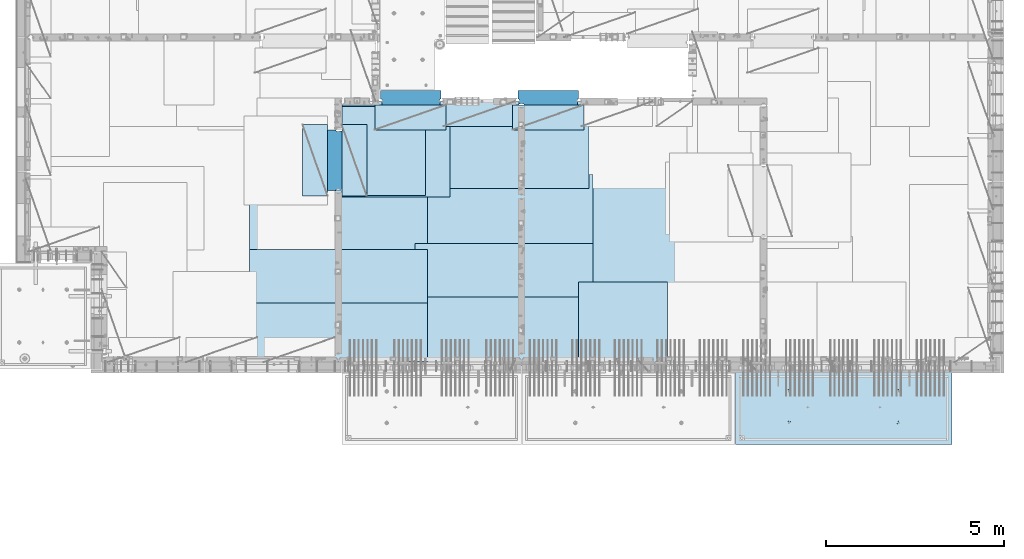
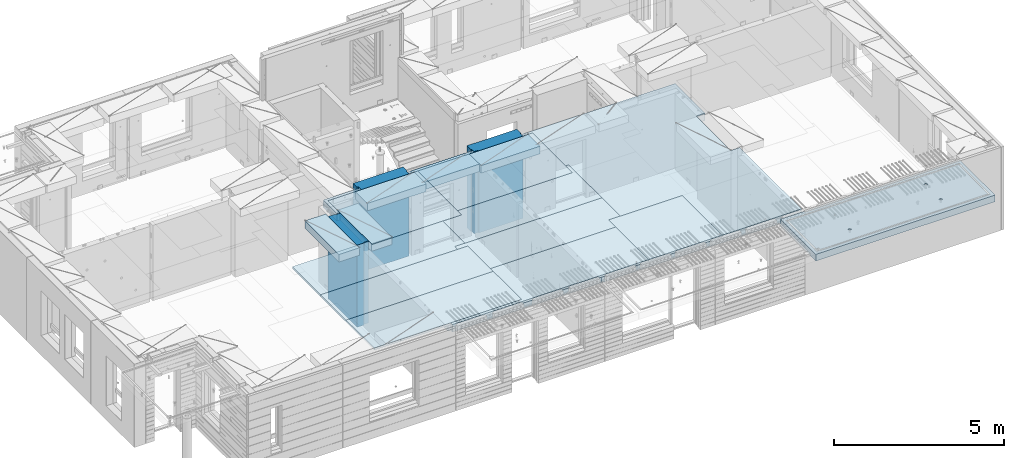
# One storey, part 197 of 341: 18 plates, 3 slabs, 19 elements without a shape of their own.
"""IFC2X3 building model written with IfcOpenShell, lengths in millimetres."""

from ifc_helpers import new_model, si_unit, frame, origin_with_axes, place, context, subcontext, project, spatial, faceted_brep, material, type_object, element, aggregate, save


model = new_model("IFC2X3")

# Units and contexts
model_context = context("Model", 3, precision=1e-05, world=origin_with_axes())
body_context = subcontext(model_context, "Body", "Model", "MODEL_VIEW")
ifc_project = project(units=[si_unit("LENGTHUNIT", "METRE", prefix="MILLI"), si_unit("AREAUNIT", "SQUARE_METRE"), si_unit("VOLUMEUNIT", "CUBIC_METRE"), si_unit("MASSUNIT", "GRAM", prefix="KILO"), si_unit("TIMEUNIT", "SECOND"), si_unit("PLANEANGLEUNIT", "RADIAN"), si_unit("SOLIDANGLEUNIT", "STERADIAN"), si_unit("THERMODYNAMICTEMPERATUREUNIT", "DEGREE_CELSIUS"), si_unit("LUMINOUSINTENSITYUNIT", "LUMEN")], contexts=[model_context])

# Site, building, storey
site_placement = place(None, origin_with_axes())
site = spatial("IfcSite", under=ifc_project, at=site_placement, CompositionType="ELEMENT")
building_placement = place(site_placement, origin_with_axes())
building = spatial("IfcBuilding", under=site, at=building_placement, CompositionType="ELEMENT")
storey_placement = place(building_placement, origin_with_axes())
storey = spatial("IfcBuildingStorey", under=building, at=storey_placement, Name="5", CompositionType="ELEMENT", Elevation=0.0)

# Assembly, slab
assembly_1_placement = place(storey_placement, origin_with_axes())
assembly_1 = element("IfcElementAssembly", 1, at=assembly_1_placement, inside=storey, AssemblyPlace="NOTDEFINED", PredefinedType="REINFORCEMENT_UNIT")
ifc_material_1 = material(Name="CONCRETE/C30/37")
slab_type_1 = type_object("IfcSlabType", PredefinedType="NOTDEFINED")
slab_1_placement = place(assembly_1_placement, frame((21810.0, 7750.0, 96595.0), z_axis=(0.0, 1.0, 0.0), x_axis=(1.0, 0.0, 0.0)))
slab_1 = element("IfcSlab", 2, at=slab_1_placement, type_object=slab_type_1, material=ifc_material_1, PredefinedType="FLOOR", context=body_context, shape_type="Brep", body=[
    faceted_brep([(6500.0, -135.0, 5637.99963378906), (6500.0, 135.0, 5637.99963378906), (6500.0, 135.0, 5680.0), (6500.0, -135.0, 5680.0), (6800.0, -135.0, 5680.0), (6800.0, 135.0, 5680.0), (6800.0, -135.0, 3637.99963378906), (6800.0, 135.0, 3637.99963378906), (6500.0, 135.0, 3637.99963378906), (6500.0, -135.0, 3637.99963378906), (6800.0, -135.0, 0.0), (6800.0, 135.0, 0.0), (1.81898940354586e-12, -135.0, 1.81898940354586e-12), (1.81898940354586e-12, 135.0, 1.81898940354586e-12), (0.0, -135.0, 7330.0), (0.0, 135.0, 7330.0), (1569.99914550782, -135.0, 7330.0), (1569.99914550782, 135.0, 7330.0), (1569.99914550782, -135.0, 7430.0), (1569.99914550782, 135.0, 7430.0), (6800.0, -135.0, 7430.0), (6800.0, 135.0, 7430.0), (6500.0, 135.0, 3780.0), (6500.0, -135.0, 3780.0)], [[[0, 1, 2, 3]], [[4, 3, 2, 5]], [[6, 7, 8, 9]], [[10, 11, 7, 6]], [[10, 12, 13, 11]], [[12, 14, 15, 13]], [[16, 17, 15, 14]], [[18, 19, 17, 16]], [[20, 21, 19, 18]], [[21, 20, 4, 5]], [[1, 22, 8, 7, 11, 13, 15, 17, 19, 21, 5, 2]], [[23, 9, 8, 22, 1, 0]], [[20, 18, 16, 14, 12, 10, 6, 9, 23, 0, 3, 4]]]),
])

assembly_2_placement = place(storey_placement, origin_with_axes())
assembly_2 = element("IfcElementAssembly", 3, at=assembly_2_placement, inside=storey, AssemblyPlace="NOTDEFINED", PredefinedType="REINFORCEMENT_UNIT")
ifc_material_2 = material(Name="CONCRETE/C35/45")
slab_type_2 = type_object("IfcSlabType", PredefinedType="NOTDEFINED")
slab_2_placement = place(assembly_2_placement, frame((33909.9998568133, 7629.99655735226, 96590.0), z_axis=(-1.11800000013248e-06, -0.999999999999375, 0.0), x_axis=(-0.999999999999093, 1.34699999998405e-06, 0.0)))
slab_2 = element("IfcSlab", 4, at=slab_2_placement, type_object=slab_type_2, material=ifc_material_2, PredefinedType="FLOOR", context=body_context, shape_type="Brep", body=[
    faceted_brep([(4605.44993885855, -113.0, 552.448239707288), (4619.38834372919, -113.0, 559.550231553701), (4630.44991833371, -113.0, 570.61183115741), (4637.55187867931, -113.0, 584.55025207851), (4639.99903540509, -113.0, 600.001104562554), (4637.55184376039, -113.0, 615.451951515985), (4630.44985191398, -113.0, 629.39035638662), (4619.38825231027, -113.0, 640.451930991143), (4605.44983138917, -113.0, 647.553891336743), (4589.99897890513, -113.0, 650.001048062522), (4574.54813195169, -113.0, 647.553856417822), (4560.60972708106, -113.0, 640.451864571409), (4549.54815247653, -113.0, 629.390264967699), (4542.44619213093, -113.0, 615.451844046599), (4539.99903540516, -113.0, 600.000991562554), (4542.44622704986, -113.0, 584.550144609124), (4549.54821889627, -113.0, 570.61173973849), (4560.60981849998, -113.0, 559.550165133966), (4574.54823942108, -113.0, 552.448204788368), (4589.99909190512, -113.0, 550.001048062586), (4548.90468317908, -120.0, 570.144182560607), (4541.68970509875, -120.0, 584.304334781456), (4560.14226277649, -120.0, 558.906628360102), (4574.30243130315, -120.0, 551.691682281732), (4589.99909280399, -120.0, 549.205593517132), (4605.69574868622, -120.0, 551.691717756181), (4619.85590090707, -120.0, 558.906695836513), (4631.09345510757, -120.0, 570.14427543392), (4638.30840118594, -120.0, 584.304443960583), (4640.79448995055, -120.0, 600.001105461418), (4638.30836571149, -120.0, 615.697761343653), (4631.09338763116, -120.0, 629.857913564502), (4619.85580803376, -120.0, 641.095467765007), (4605.6956395071, -120.0, 648.310413843377), (4589.99897800626, -120.0, 650.796502607977), (4574.30232212402, -120.0, 648.310378368928), (4560.14216990317, -120.0, 641.095400288596), (4548.90461570267, -120.0, 629.85782069119), (4541.6896696243, -120.0, 615.697652164527), (4539.2035808597, -120.0, 600.000990663691), (0.000819232023786753, -120.0, 2085.00366210938), (6090.0009765625, -120.0, 2085.00366210938), (6090.0009765625, 120.0, 2085.00366210938), (0.000819232023786753, 120.0, 2085.00366210938), (6090.0, -120.0, 1.39971234602854e-09), (6090.0, 120.0, 1.39971234602854e-09), (-7.27595761418343e-12, -120.0, -9.09494701772928e-13), (-7.27595761418343e-12, 120.0, -9.09494701772928e-13), (1515.44893888152, -108.0, 1437.45474794476), (1529.38734375216, -108.0, 1444.55673979117), (1540.44891835668, -108.0, 1455.61833939488), (1547.55087870228, -108.0, 1469.55676031598), (1549.99803542806, -108.0, 1485.00761280002), (1547.55084378336, -108.0, 1500.45845975345), (1540.44885193695, -108.0, 1514.39686462409), (1529.38725233324, -108.0, 1525.45843922861), (1515.44883141214, -108.0, 1532.56039957421), (1499.99797892809, -108.0, 1535.00755629999), (1484.54713197466, -108.0, 1532.56036465529), (1470.60872710403, -108.0, 1525.45837280888), (1459.5471524995, -108.0, 1514.39677320517), (1452.44519215391, -108.0, 1500.45835228407), (1449.99803542813, -108.0, 1485.00749980002), (1452.44522707283, -108.0, 1469.55665284659), (1459.54721891924, -108.0, 1455.61824797596), (1470.60881852295, -108.0, 1444.55667337144), (1484.54723944405, -108.0, 1437.45471302584), (1499.99809192809, -108.0, 1435.00755630005), (1451.1483322995, -120.0, 1469.13526457059), (1448.63439906449, -120.0, 1485.00749825911), (1458.44401483263, -120.0, 1454.8167213853), (1469.80729442553, -120.0, 1443.45346747338), (1484.12585409903, -120.0, 1436.15781730018), (1499.998093469, -120.0, 1433.64391993642), (1515.87032715753, -120.0, 1436.15785317143), (1530.18887034281, -120.0, 1443.45353570456), (1541.55212425473, -120.0, 1454.81681529746), (1548.84777442794, -120.0, 1469.13537497096), (1551.3616717917, -120.0, 1485.00761434093), (1548.84773855669, -120.0, 1500.87984802946), (1541.55205602355, -120.0, 1515.19839121474), (1530.18877643065, -120.0, 1526.56164512666), (1515.87021675716, -120.0, 1533.85729529987), (1499.99797738718, -120.0, 1536.37119266363), (1484.12574369866, -120.0, 1533.85725942862), (1469.80720051337, -120.0, 1526.56157689548), (1458.44394660145, -120.0, 1515.19829730258), (1451.14829642824, -120.0, 1500.87973762909), (1515.44993893152, -113.0, 552.45474794532), (1529.38834380215, -113.0, 559.556739791733), (1540.44991840668, -113.0, 570.618339395443), (1547.55187875228, -113.0, 584.556760316543), (1549.99903547806, -113.0, 600.007612800588), (1547.55184383336, -113.0, 615.458459754018), (1540.44985198694, -113.0, 629.396864624653), (1529.38825238323, -113.0, 640.458439229175), (1515.44983146213, -113.0, 647.560399574775), (1499.99897897809, -113.0, 650.007556300556), (1484.54813202466, -113.0, 647.560364655855), (1470.60972715402, -113.0, 640.458372809442), (1459.5481525495, -113.0, 629.396773205733), (1452.4461922039, -113.0, 615.458352284632), (1449.99903547812, -113.0, 600.007499800588), (1452.44622712283, -113.0, 584.556652847157), (1459.54821896923, -113.0, 570.618247976523), (1470.60981857295, -113.0, 559.556673372), (1484.54823949404, -113.0, 552.4547130264), (1499.99909197809, -113.0, 550.007556300619), (1451.68970517172, -120.0, 584.310843019489), (1449.20358093267, -120.0, 600.007498901724), (1458.90468325205, -120.0, 570.15069079864), (1470.14226284945, -120.0, 558.913136598135), (1484.30243137612, -120.0, 551.698190519764), (1499.99909287695, -120.0, 549.212101755165), (1515.69574875919, -120.0, 551.698225994213), (1529.85590098004, -120.0, 558.913204074546), (1541.09345518054, -120.0, 570.150783671952), (1548.30840125891, -120.0, 584.310952198615), (1550.79449002351, -120.0, 600.007613699451), (1548.30836578447, -120.0, 615.704269581685), (1541.09338770413, -120.0, 629.864421802535), (1529.85580810672, -120.0, 641.10197600304), (1515.69563958006, -120.0, 648.31692208141), (1499.99897807923, -120.0, 650.803010846011), (1484.30232219699, -120.0, 648.316886606961), (1470.14216997614, -120.0, 641.101908526629), (1458.90461577564, -120.0, 629.864328929222), (1451.68966969727, -120.0, 615.704160402559), (4605.44893880856, -108.0, 1437.44823970672), (4619.38734367919, -108.0, 1444.55023155314), (4630.44891828372, -108.0, 1455.61183115685), (4637.55087862931, -108.0, 1469.55025207795), (4639.99803535509, -108.0, 1485.00110456199), (4637.55084371039, -108.0, 1500.45195151542), (4630.44885186398, -108.0, 1514.39035638605), (4619.38725226027, -108.0, 1525.45193099058), (4605.44883133917, -108.0, 1532.55389133618), (4589.99797885512, -108.0, 1535.00104806196), (4574.54713190169, -108.0, 1532.55385641726), (4560.60872703106, -108.0, 1525.45186457084), (4549.54715242653, -108.0, 1514.39026496713), (4542.44519208094, -108.0, 1500.45184404603), (4539.99803535516, -108.0, 1485.00099156199), (4542.44522699986, -108.0, 1469.55014460856), (4549.54721884627, -108.0, 1455.61173973792), (4560.60881844998, -108.0, 1444.5501651334), (4574.54723937108, -108.0, 1437.4482047878), (4589.99809185513, -108.0, 1435.00104806202), (4541.14833222653, -120.0, 1469.12875633256), (4538.63439899152, -120.0, 1485.00099002108), (4548.44401475967, -120.0, 1454.81021314727), (4559.80729435257, -120.0, 1443.44695923535), (4574.12585402606, -120.0, 1436.15130906214), (4589.99809339604, -120.0, 1433.63741169839), (4605.87032708456, -120.0, 1436.1513449334), (4620.18887026985, -120.0, 1443.44702746653), (4631.55212418177, -120.0, 1454.81030705943), (4638.84777435497, -120.0, 1469.12886673293), (4641.36167171873, -120.0, 1485.0011061029), (4638.84773848372, -120.0, 1500.87333979142), (4631.55205595059, -120.0, 1515.19188297671), (4620.18877635769, -120.0, 1526.55513688863), (4605.87021668419, -120.0, 1533.85078706184), (4589.99797731422, -120.0, 1536.36468442559), (4574.12574362569, -120.0, 1533.85075119058), (4559.80720044041, -120.0, 1526.55506865745), (4548.44394652849, -120.0, 1515.19178906455), (4541.14829635528, -120.0, 1500.87322939105)], [[[0, 1, 2, 3, 4, 5, 6, 7, 8, 9, 10, 11, 12, 13, 14, 15, 16, 17, 18, 19]], [[20, 16, 15, 21]], [[22, 17, 16, 20]], [[23, 18, 17, 22]], [[24, 19, 18, 23]], [[25, 0, 19, 24]], [[26, 1, 0, 25]], [[27, 2, 1, 26]], [[28, 3, 2, 27]], [[29, 4, 3, 28]], [[30, 5, 4, 29]], [[31, 6, 5, 30]], [[32, 7, 6, 31]], [[33, 8, 7, 32]], [[34, 9, 8, 33]], [[35, 10, 9, 34]], [[36, 11, 10, 35]], [[37, 12, 11, 36]], [[38, 13, 12, 37]], [[39, 14, 13, 38]], [[21, 15, 14, 39]], [[40, 41, 42, 43]], [[41, 44, 45, 42]], [[44, 46, 47, 45]], [[42, 45, 47, 43]], [[46, 40, 43, 47]], [[48, 49, 50, 51, 52, 53, 54, 55, 56, 57, 58, 59, 60, 61, 62, 63, 64, 65, 66, 67]], [[68, 63, 62, 69]], [[70, 64, 63, 68]], [[71, 65, 64, 70]], [[72, 66, 65, 71]], [[73, 67, 66, 72]], [[74, 48, 67, 73]], [[75, 49, 48, 74]], [[76, 50, 49, 75]], [[77, 51, 50, 76]], [[78, 52, 51, 77]], [[79, 53, 52, 78]], [[80, 54, 53, 79]], [[81, 55, 54, 80]], [[82, 56, 55, 81]], [[83, 57, 56, 82]], [[84, 58, 57, 83]], [[85, 59, 58, 84]], [[86, 60, 59, 85]], [[87, 61, 60, 86]], [[69, 62, 61, 87]], [[88, 89, 90, 91, 92, 93, 94, 95, 96, 97, 98, 99, 100, 101, 102, 103, 104, 105, 106, 107]], [[108, 103, 102, 109]], [[110, 104, 103, 108]], [[111, 105, 104, 110]], [[112, 106, 105, 111]], [[113, 107, 106, 112]], [[114, 88, 107, 113]], [[115, 89, 88, 114]], [[116, 90, 89, 115]], [[117, 91, 90, 116]], [[118, 92, 91, 117]], [[119, 93, 92, 118]], [[120, 94, 93, 119]], [[121, 95, 94, 120]], [[122, 96, 95, 121]], [[123, 97, 96, 122]], [[124, 98, 97, 123]], [[125, 99, 98, 124]], [[126, 100, 99, 125]], [[127, 101, 100, 126]], [[109, 102, 101, 127]], [[128, 129, 130, 131, 132, 133, 134, 135, 136, 137, 138, 139, 140, 141, 142, 143, 144, 145, 146, 147]], [[148, 143, 142, 149]], [[150, 144, 143, 148]], [[151, 145, 144, 150]], [[152, 146, 145, 151]], [[153, 147, 146, 152]], [[154, 128, 147, 153]], [[155, 129, 128, 154]], [[156, 130, 129, 155]], [[157, 131, 130, 156]], [[158, 132, 131, 157]], [[159, 133, 132, 158]], [[160, 134, 133, 159]], [[161, 135, 134, 160]], [[162, 136, 135, 161]], [[163, 137, 136, 162]], [[164, 138, 137, 163]], [[165, 139, 138, 164]], [[166, 140, 139, 165]], [[167, 141, 140, 166]], [[149, 142, 141, 167]], [[44, 41, 40, 46], [37, 36, 35, 34, 33, 32, 31, 30, 29, 28, 27, 26, 25, 24, 23, 22, 20, 21, 39, 38], [166, 165, 164, 163, 162, 161, 160, 159, 158, 157, 156, 155, 154, 153, 152, 151, 150, 148, 149, 167], [126, 125, 124, 123, 122, 121, 120, 119, 118, 117, 116, 115, 114, 113, 112, 111, 110, 108, 109, 127], [86, 85, 84, 83, 82, 81, 80, 79, 78, 77, 76, 75, 74, 73, 72, 71, 70, 68, 69, 87]]]),
])
aggregate(assembly_2, [slab_2])

# Assembly, plate
assembly_3_placement = place(storey_placement, origin_with_axes())
assembly_3 = element("IfcElementAssembly", 5, at=assembly_3_placement, inside=storey, Name="Steel Assembly", AssemblyPlace="NOTDEFINED", PredefinedType="NOTDEFINED")
ifc_material_3 = material()
plate_type_1 = type_object("IfcPlateType", PredefinedType="NOTDEFINED")
plate_1_placement = place(assembly_3_placement, frame((25910.0, 7750.0, 96695.1), z_axis=(-1.0, 3.00000001838171e-08, 0.0), x_axis=(0.0, 1.0, 0.0)))
plate_1 = element("IfcPlate", 6, at=plate_1_placement, type_object=plate_type_1, material=ifc_material_3, Name="1/2", context=body_context, shape_type="Brep", body=[
    faceted_brep([(0.0, -35.0, 0.0), (0.0, -35.0, 2500.0), (0.0, 35.0, 2500.0), (0.0, 35.0, 0.0), (2349.99951171875, -35.0, 2500.0), (2349.99951171875, 35.0, 2500.0), (2350.0, -35.0, 0.0), (2350.0, 35.0, 0.0)], [[[0, 1, 2, 3]], [[1, 4, 5, 2]], [[4, 6, 7, 5]], [[6, 0, 3, 7]], [[5, 7, 3, 2]], [[6, 4, 1, 0]]]),
])
aggregate(assembly_3, [plate_1])

assembly_4_placement = place(storey_placement, origin_with_axes())
assembly_4 = element("IfcElementAssembly", 7, at=assembly_4_placement, inside=storey, Name="Steel Assembly", AssemblyPlace="NOTDEFINED", PredefinedType="NOTDEFINED")
plate_2_placement = place(assembly_4_placement, frame((16759.9995320312, 12530.0000289158, 96695.1), z_axis=(0.0, 1.0, 0.0), x_axis=(1.0, 0.0, 0.0)))
plate_2 = element("IfcPlate", 8, at=plate_2_placement, type_object=plate_type_1, material=ifc_material_3, Name="1/2", context=body_context, shape_type="Brep", body=[
    faceted_brep([(0.0, -35.0, 0.0), (0.0, -35.0, 2500.0), (0.0, 35.0, 2500.0), (0.0, 35.0, 0.0), (2349.99951171875, -35.0, 2500.0), (2349.99951171875, 35.0, 2500.0), (2350.0, -35.0, 0.0), (2350.0, 35.0, 0.0)], [[[0, 1, 2, 3]], [[1, 4, 5, 2]], [[4, 6, 7, 5]], [[6, 0, 3, 7]], [[5, 7, 3, 2]], [[6, 4, 1, 0]]]),
])
aggregate(assembly_4, [plate_2])

assembly_5_placement = place(storey_placement, origin_with_axes())
assembly_5 = element("IfcElementAssembly", 9, at=assembly_5_placement, inside=storey, Name="Steel Assembly", AssemblyPlace="NOTDEFINED", PredefinedType="NOTDEFINED")
plate_3_placement = place(assembly_5_placement, frame((23810.0, 10780.0, 96695.1), z_axis=(-1.0, 3.00000001838171e-08, 0.0), x_axis=(0.0, 1.0, 0.0)))
plate_3 = element("IfcPlate", 10, at=plate_3_placement, type_object=plate_type_1, material=ifc_material_3, context=body_context, shape_type="Brep", body=[
    faceted_brep([(0.0, -35.0, 0.0), (0.0, -35.0, 5000.0), (0.0, 35.0, 5000.0), (0.0, 35.0, 0.0), (2349.99951171875, -35.0, 5000.0), (2349.99951171875, 35.0, 5000.0), (2350.0, -35.0, 0.0), (2350.0, 35.0, 0.0)], [[[0, 1, 2, 3]], [[1, 4, 5, 2]], [[4, 6, 7, 5]], [[6, 0, 3, 7]], [[5, 7, 3, 2]], [[6, 4, 1, 0]]]),
])
aggregate(assembly_5, [plate_3])

assembly_6_placement = place(storey_placement, origin_with_axes())
assembly_6 = element("IfcElementAssembly", 11, at=assembly_6_placement, inside=storey, Name="Steel Assembly", AssemblyPlace="NOTDEFINED", PredefinedType="NOTDEFINED")
plate_4_placement = place(assembly_6_placement, frame((23710.0, 12730.0, 96695.1), z_axis=(-1.0, 3.00000001838171e-08, 0.0), x_axis=(0.0, 1.0, 0.0)))
plate_4 = element("IfcPlate", 12, at=plate_4_placement, type_object=plate_type_1, material=ifc_material_3, context=body_context, shape_type="Brep", body=[
    faceted_brep([(0.0, -35.0, 0.0), (0.0, -35.0, 5000.0), (0.0, 35.0, 5000.0), (0.0, 35.0, 0.0), (2349.99951171875, -35.0, 5000.0), (2349.99951171875, 35.0, 5000.0), (2350.0, -35.0, 0.0), (2350.0, 35.0, 0.0)], [[[0, 1, 2, 3]], [[1, 4, 5, 2]], [[4, 6, 7, 5]], [[6, 0, 3, 7]], [[5, 7, 3, 2]], [[6, 4, 1, 0]]]),
])
aggregate(assembly_6, [plate_4])

assembly_7_placement = place(storey_placement, origin_with_axes())
assembly_7 = element("IfcElementAssembly", 13, at=assembly_7_placement, inside=storey, Name="Steel Assembly", AssemblyPlace="NOTDEFINED", PredefinedType="NOTDEFINED")
plate_5_placement = place(assembly_7_placement, frame((23810.0, 7750.0, 96695.1), z_axis=(-1.0, 3.00000001838171e-08, 0.0), x_axis=(0.0, 1.0, 0.0)))
plate_5 = element("IfcPlate", 14, at=plate_5_placement, type_object=plate_type_1, material=ifc_material_3, context=body_context, shape_type="Brep", body=[
    faceted_brep([(0.0, -35.0, 0.0), (0.0, -35.0, 5000.0), (0.0, 35.0, 5000.0), (0.0, 35.0, 0.0), (2349.99951171875, -35.0, 5000.0), (2349.99951171875, 35.0, 5000.0), (2350.0, -35.0, 0.0), (2350.0, 35.0, 0.0)], [[[0, 1, 2, 3]], [[1, 4, 5, 2]], [[4, 6, 7, 5]], [[6, 0, 3, 7]], [[5, 7, 3, 2]], [[6, 4, 1, 0]]]),
])
aggregate(assembly_7, [plate_5])

assembly_8_placement = place(storey_placement, origin_with_axes())
assembly_8 = element("IfcElementAssembly", 15, at=assembly_8_placement, inside=storey, Name="Steel Assembly", AssemblyPlace="NOTDEFINED", PredefinedType="NOTDEFINED")
plate_6_placement = place(assembly_8_placement, frame((19160.0, 10325.0, 96695.1), z_axis=(-1.0, 3.00000001838171e-08, 0.0), x_axis=(0.0, 1.0, 0.0)))
plate_6 = element("IfcPlate", 16, at=plate_6_placement, type_object=plate_type_1, material=ifc_material_3, context=body_context, shape_type="Brep", body=[
    faceted_brep([(0.0, -35.0, 0.0), (0.0, -35.0, 5000.0), (0.0, 35.0, 5000.0), (0.0, 35.0, 0.0), (2349.99951171875, -35.0, 5000.0), (2349.99951171875, 35.0, 5000.0), (2350.0, -35.0, 0.0), (2350.0, 35.0, 0.0)], [[[0, 1, 2, 3]], [[1, 4, 5, 2]], [[4, 6, 7, 5]], [[6, 0, 3, 7]], [[5, 7, 3, 2]], [[6, 4, 1, 0]]]),
])
aggregate(assembly_8, [plate_6])

assembly_9_placement = place(storey_placement, origin_with_axes())
assembly_9 = element("IfcElementAssembly", 17, at=assembly_9_placement, inside=storey, Name="Steel Assembly", AssemblyPlace="NOTDEFINED", PredefinedType="NOTDEFINED")
plate_7_placement = place(assembly_9_placement, frame((19160.0, 7850.0, 96695.1), z_axis=(-1.0, 3.00000001838171e-08, 0.0), x_axis=(0.0, 1.0, 0.0)))
plate_7 = element("IfcPlate", 18, at=plate_7_placement, type_object=plate_type_1, material=ifc_material_3, context=body_context, shape_type="Brep", body=[
    faceted_brep([(0.0, -35.0, 0.0), (0.0, -35.0, 5000.0), (0.0, 35.0, 5000.0), (0.0, 35.0, 0.0), (2349.99951171875, -35.0, 5000.0), (2349.99951171875, 35.0, 5000.0), (2350.0, -35.0, 0.0), (2350.0, 35.0, 0.0)], [[[0, 1, 2, 3]], [[1, 4, 5, 2]], [[4, 6, 7, 5]], [[6, 0, 3, 7]], [[5, 7, 3, 2]], [[6, 4, 1, 0]]]),
])
aggregate(assembly_9, [plate_7])

assembly_10_placement = place(storey_placement, origin_with_axes())
assembly_10 = element("IfcElementAssembly", 19, at=assembly_10_placement, inside=storey, Name="Steel Assembly", AssemblyPlace="NOTDEFINED", PredefinedType="NOTDEFINED")
plate_type_2 = type_object("IfcPlateType", PredefinedType="NOTDEFINED")
plate_8_placement = place(assembly_10_placement, frame((18810.0, 11180.0000122641, 96695.1000003815), z_axis=(1.0, 0.0, 0.0), x_axis=(0.0, -1.0, 0.0)))
plate_8 = element("IfcPlate", 20, at=plate_8_placement, type_object=plate_type_2, material=ifc_material_3, context=body_context, shape_type="Brep", body=[
    faceted_brep([(0.0, -35.0, 0.0), (0.0, -35.0, 5000.0), (0.0, 35.0, 5000.0), (0.0, 35.0, 0.0), (1499.99951171875, -35.0, 5000.0), (1499.99951171875, 35.0, 5000.0), (1500.0, -35.0, 0.0), (1500.0, 35.0, 0.0)], [[[0, 1, 2, 3]], [[1, 4, 5, 2]], [[4, 6, 7, 5]], [[6, 0, 3, 7]], [[5, 7, 3, 2]], [[6, 4, 1, 0]]]),
])
aggregate(assembly_10, [plate_8])

assembly_11_placement = place(storey_placement, origin_with_axes())
assembly_11 = element("IfcElementAssembly", 21, at=assembly_11_placement, inside=storey, Name="Steel Assembly", AssemblyPlace="NOTDEFINED", PredefinedType="NOTDEFINED")
plate_9_placement = place(assembly_11_placement, frame((14160.0, 11015.0000122641, 96695.1000003815), z_axis=(1.0, 0.0, 0.0), x_axis=(0.0, -1.0, 0.0)))
plate_9 = element("IfcPlate", 22, at=plate_9_placement, type_object=plate_type_2, material=ifc_material_3, context=body_context, shape_type="Brep", body=[
    faceted_brep([(0.0, -35.0, 0.0), (0.0, -35.0, 5000.0), (0.0, 35.0, 5000.0), (0.0, 35.0, 0.0), (1499.99951171875, -35.0, 5000.0), (1499.99951171875, 35.0, 5000.0), (1500.0, -35.0, 0.0), (1500.0, 35.0, 0.0)], [[[0, 1, 2, 3]], [[1, 4, 5, 2]], [[4, 6, 7, 5]], [[6, 0, 3, 7]], [[5, 7, 3, 2]], [[6, 4, 1, 0]]]),
])
aggregate(assembly_11, [plate_9])

assembly_12_placement = place(storey_placement, origin_with_axes())
assembly_12 = element("IfcElementAssembly", 23, at=assembly_12_placement, inside=storey, Name="Steel Assembly", AssemblyPlace="NOTDEFINED", PredefinedType="NOTDEFINED")
plate_type_3 = type_object("IfcPlateType", PredefinedType="NOTDEFINED")
plate_10_placement = place(assembly_12_placement, frame((16759.9998779297, 14525.0, 96595.3), z_axis=(1.0, 0.0, 0.0), x_axis=(0.0, -1.0, 0.0)))
plate_10 = element("IfcPlate", 24, at=plate_10_placement, type_object=plate_type_3, material=ifc_material_3, Name="RE1", context=body_context, shape_type="Brep", body=[
    faceted_brep([(1.81898940354586e-12, -135.0, 1.81898940354586e-12), (0.0, -135.0, 699.999999999996), (0.0, 135.0, 699.999999999996), (1.81898940354586e-12, 135.0, 1.81898940354586e-12), (1999.99951171875, -135.0, 699.999999999993), (1999.99951171875, 135.0, 699.999999999993), (2000.0, -135.0, -3.63797880709171e-12), (2000.0, 135.0, -3.63797880709171e-12)], [[[0, 1, 2, 3]], [[1, 4, 5, 2]], [[4, 6, 7, 5]], [[6, 0, 3, 7]], [[5, 7, 3, 2]], [[6, 4, 1, 0]]]),
])
aggregate(assembly_12, [plate_10])

assembly_13_placement = place(storey_placement, origin_with_axes())
assembly_13 = element("IfcElementAssembly", 25, at=assembly_13_placement, inside=storey, Name="Steel Assembly", AssemblyPlace="NOTDEFINED", PredefinedType="NOTDEFINED")
plate_11_placement = place(assembly_13_placement, frame((16359.7701220703, 12525.0, 96595.3), z_axis=(-1.0, 3.00000001838171e-08, 0.0), x_axis=(0.0, 1.0, 0.0)))
plate_11 = element("IfcPlate", 26, at=plate_11_placement, type_object=plate_type_3, material=ifc_material_3, Name="RE1", context=body_context, shape_type="Brep", body=[
    faceted_brep([(1.81898940354586e-12, -135.0, 1.81898940354586e-12), (0.0, -135.0, 699.999999999996), (0.0, 135.0, 699.999999999996), (1.81898940354586e-12, 135.0, 1.81898940354586e-12), (1999.99951171875, -135.0, 699.999999999993), (1999.99951171875, 135.0, 699.999999999993), (2000.0, -135.0, -3.63797880709171e-12), (2000.0, 135.0, -3.63797880709171e-12)], [[[0, 1, 2, 3]], [[1, 4, 5, 2]], [[4, 6, 7, 5]], [[6, 0, 3, 7]], [[5, 7, 3, 2]], [[6, 4, 1, 0]]]),
])
aggregate(assembly_13, [plate_11])

assembly_14_placement = place(storey_placement, origin_with_axes())
assembly_14 = element("IfcElementAssembly", 27, at=assembly_14_placement, inside=storey, Name="Steel Assembly", AssemblyPlace="NOTDEFINED", PredefinedType="NOTDEFINED")
plate_12_placement = place(assembly_14_placement, frame((21624.9991457614, 15179.9998963664, 96595.3), z_axis=(0.0, -1.0, 0.0), x_axis=(-1.0, 3.00000001838171e-08, 0.0)))
plate_12 = element("IfcPlate", 28, at=plate_12_placement, type_object=plate_type_3, material=ifc_material_3, Name="RE1", context=body_context, shape_type="Brep", body=[
    faceted_brep([(1.81898940354586e-12, -135.0, 1.81898940354586e-12), (0.0, -135.0, 699.999999999996), (0.0, 135.0, 699.999999999996), (1.81898940354586e-12, 135.0, 1.81898940354586e-12), (1999.99951171875, -135.0, 699.999999999993), (1999.99951171875, 135.0, 699.999999999993), (2000.0, -135.0, -3.63797880709171e-12), (2000.0, 135.0, -3.63797880709171e-12)], [[[0, 1, 2, 3]], [[1, 4, 5, 2]], [[4, 6, 7, 5]], [[6, 0, 3, 7]], [[5, 7, 3, 2]], [[6, 4, 1, 0]]]),
])
aggregate(assembly_14, [plate_12])

assembly_15_placement = place(storey_placement, origin_with_axes())
assembly_15 = element("IfcElementAssembly", 29, at=assembly_15_placement, inside=storey, Name="Steel Assembly", AssemblyPlace="NOTDEFINED", PredefinedType="NOTDEFINED")
plate_13_placement = place(assembly_15_placement, frame((23559.9991457614, 15079.9998963664, 96595.3), z_axis=(0.0, -1.0, 0.0), x_axis=(-1.0, 3.00000001838171e-08, 0.0)))
plate_13 = element("IfcPlate", 30, at=plate_13_placement, type_object=plate_type_3, material=ifc_material_3, Name="RE1", context=body_context, shape_type="Brep", body=[
    faceted_brep([(1.81898940354586e-12, -135.0, 1.81898940354586e-12), (0.0, -135.0, 699.999999999996), (0.0, 135.0, 699.999999999996), (1.81898940354586e-12, 135.0, 1.81898940354586e-12), (1999.99951171875, -135.0, 699.999999999993), (1999.99951171875, 135.0, 699.999999999993), (2000.0, -135.0, -3.63797880709171e-12), (2000.0, 135.0, -3.63797880709171e-12)], [[[0, 1, 2, 3]], [[1, 4, 5, 2]], [[4, 6, 7, 5]], [[6, 0, 3, 7]], [[5, 7, 3, 2]], [[6, 4, 1, 0]]]),
])
aggregate(assembly_15, [plate_13])

assembly_16_placement = place(storey_placement, origin_with_axes())
assembly_16 = element("IfcElementAssembly", 31, at=assembly_16_placement, inside=storey, Name="Steel Assembly", AssemblyPlace="NOTDEFINED", PredefinedType="NOTDEFINED")
plate_14_placement = place(assembly_16_placement, frame((19689.9991457614, 15079.9998963664, 96595.3), z_axis=(0.0, -1.0, 0.0), x_axis=(-1.0, 3.00000001838171e-08, 0.0)))
plate_14 = element("IfcPlate", 32, at=plate_14_placement, type_object=plate_type_3, material=ifc_material_3, Name="RE1", context=body_context, shape_type="Brep", body=[
    faceted_brep([(1.81898940354586e-12, -135.0, 1.81898940354586e-12), (0.0, -135.0, 699.999999999996), (0.0, 135.0, 699.999999999996), (1.81898940354586e-12, 135.0, 1.81898940354586e-12), (1999.99951171875, -135.0, 699.999999999993), (1999.99951171875, 135.0, 699.999999999993), (2000.0, -135.0, -3.63797880709171e-12), (2000.0, 135.0, -3.63797880709171e-12)], [[[0, 1, 2, 3]], [[1, 4, 5, 2]], [[4, 6, 7, 5]], [[6, 0, 3, 7]], [[5, 7, 3, 2]], [[6, 4, 1, 0]]]),
])
aggregate(assembly_16, [plate_14])

# Plate
plate_type_4 = type_object("IfcPlateType", PredefinedType="NOTDEFINED")
plate_15_placement = place(assembly_1_placement, frame((16760.0002457424, 12487.9997681111, 96725.45), z_axis=(0.0, 1.0, 0.0), x_axis=(1.0, 0.0, 0.0)))
plate_15 = element("IfcPlate", 33, at=plate_15_placement, type_object=plate_type_4, material=ifc_material_3, context=body_context, shape_type="Brep", body=[
    faceted_brep([(0.0, -5.0, 0.0), (0.0, -5.0, 2592.0), (0.0, 5.0, 2592.0), (0.0, 5.0, 0.0), (3041.99975585938, -5.0, 2592.0), (3041.99975585938, 5.0, 2592.0), (3041.99975585938, -5.0, 0.0), (3041.99975585938, 5.0, 0.0)], [[[0, 1, 2, 3]], [[1, 4, 5, 2]], [[4, 6, 7, 5]], [[6, 0, 3, 7]], [[5, 7, 3, 2]], [[6, 4, 1, 0]]]),
])

# Slab
slab_type_3 = type_object("IfcSlabType", PredefinedType="NOTDEFINED")
slab_3_placement = place(assembly_1_placement, frame((21810.0, 15180.0, 96595.0), z_axis=(0.0, -1.0, 0.0), x_axis=(-1.0, 3.00000001838171e-08, 0.0)))
slab_3 = element("IfcSlab", 34, at=slab_3_placement, type_object=slab_type_3, material=ifc_material_1, PredefinedType="FLOOR", context=body_context, shape_type="Brep", body=[
    faceted_brep([(2300.00087620694, -135.0, -2.78342304227408e-06), (2300.00087620694, 135.0, 0.0), (2300.00087620694, 135.0, 100.000233727807), (2300.00087620694, -135.0, 100.000233727807), (3920.000509996, 135.000000000015, 100.000233727807), (3920.000509996, -135.0, 100.000233727807), (3920.00085449219, -135.0, 0.0), (3920.00085449219, 135.0, 0.0), (5150.0, 135.0, 0.0), (5150.0, -135.0, 0.0), (5150.0, 135.0, 804.999923541527), (5150.0, -135.0, 804.999923541527), (5049.99975425761, 135.0, 804.999923541527), (5049.99975425761, -135.0, 804.999923541527), (5049.99975425761, 135.0, 2504.99992354153), (5049.99975425761, -135.0, 2504.99992354153), (5150.0, 135.0, 2504.99992354153), (5150.0, -135.0, 2504.99992354153), (5150.0, 135.0, 7330.0), (5150.0, -135.0, 7330.0), (5055.0, -135.0, 7330.0), (5055.0, 135.0, 7330.0), (5055.0, -135.0, 7430.0), (5055.0, 135.0, 7430.0), (0.0, -135.0, 7430.0), (0.0, 135.0, 7430.0), (70.0000000000036, -135.0, -8.47121555125341e-08), (3.63797880709171e-12, -135.0, 100.0), (70.0000000000036, -135.000000000015, 100.0), (70.0000000000036, 135.0, 0.0), (70.0000000000036, 135.0, 100.0), (0.0, 135.0, 100.0)], [[[0, 1, 2, 3]], [[3, 2, 4, 5]], [[6, 5, 4, 7]], [[8, 9, 6, 7]], [[9, 8, 10, 11]], [[11, 10, 12, 13]], [[13, 12, 14, 15]], [[15, 14, 16, 17]], [[18, 19, 17, 16]], [[20, 19, 18, 21]], [[22, 20, 21, 23]], [[24, 22, 23, 25]], [[26, 0, 3, 5, 6, 9, 11, 13, 15, 17, 19, 20, 22, 24, 27, 28]], [[1, 0, 26, 29]], [[25, 23, 21, 18, 16, 14, 12, 10, 8, 7, 4, 2, 1, 29, 30, 31]], [[26, 28, 30, 29]], [[27, 31, 30, 28]], [[24, 25, 31, 27]]]),
])

aggregate(assembly_1, [plate_15, slab_3, slab_1])

# Assembly, plate
assembly_17_placement = place(storey_placement, origin_with_axes())
assembly_17 = element("IfcElementAssembly", 35, at=assembly_17_placement, inside=storey, Name="Steel Assembly", AssemblyPlace="NOTDEFINED", PredefinedType="NOTDEFINED")
ifc_material_4 = material()
plate_type_5 = type_object("IfcPlateType", PredefinedType="NOTDEFINED")
plate_16_placement = place(assembly_17_placement, frame((17840.0, 15080.0, 95255.6000003815), z_axis=(0.0, 1.0, 0.0), x_axis=(1.0, 0.0, 0.0)))
plate_16 = element("IfcPlate", 36, at=plate_16_placement, type_object=plate_type_5, material=ifc_material_4, context=body_context, shape_type="Brep", body=[
    faceted_brep([(49.9991463160914, -1475.0, 156.999999814216), (49.9991455078125, -1216.89999961853, 156.999999999998), (49.9994900039455, -1216.89999961853, -0.000233727812883444), (49.9994832763732, -1475.0, 0.0), (0.0, -1475.0, 170.000000230655), (-0.00085392879191204, -1216.89999961853, 170.000000368096), (0.0, -1475.0, 400.0), (1699.99914550781, -1475.0, 400.0), (1699.99914550781, 1475.0, 400.0), (0.0, 1475.0, 400.0), (1699.99914550781, -1475.0, 169.999999999998), (1699.99914550781, 1475.0, 169.999999999998), (1669.99914550781, 1475.0, 156.999999999998), (1669.99914550781, 1475.0, 3.63797880709171e-12), (49.9994900039455, 1475.0, 0.0), (49.9991455078125, 1475.0, 156.999999999998), (0.0, 1475.0, 170.000000368096), (1669.99914550781, -1475.0, 156.999999999998), (1669.99914550781, -1475.0, 3.63797880709171e-12)], [[[0, 1, 2, 3]], [[4, 5, 1, 0]], [[6, 7, 8, 9]], [[8, 7, 10, 11]], [[9, 8, 11, 12, 13, 14, 15, 16]], [[10, 17, 12, 11]], [[18, 13, 12, 17]], [[14, 13, 18, 3, 2]], [[14, 2, 1, 15]], [[15, 1, 5, 16]], [[6, 9, 16, 5, 4]], [[18, 17, 10, 7, 6, 4, 0, 3]]]),
])
aggregate(assembly_17, [plate_16])

assembly_18_placement = place(storey_placement, origin_with_axes())
assembly_18 = element("IfcElementAssembly", 37, at=assembly_18_placement, inside=storey, Name="Steel Assembly", AssemblyPlace="NOTDEFINED", PredefinedType="NOTDEFINED")
plate_17_placement = place(assembly_18_placement, frame((21710.0, 15080.0, 95255.6000003815), z_axis=(0.0, 1.0, 0.0), x_axis=(1.0, 0.0, 0.0)))
plate_17 = element("IfcPlate", 38, at=plate_17_placement, type_object=plate_type_5, material=ifc_material_4, context=body_context, shape_type="Brep", body=[
    faceted_brep([(30.0, -1475.0, 29.9998239177003), (30.0, 1475.0, 29.9998239177003), (157.0, 1475.0, 29.9998239177003), (157.0, -1475.0, 29.9998239177003), (169.999923697669, -1475.0, 0.0), (169.999923697669, 1475.0, 0.0), (0.0, -1475.0, 170.000000230655), (0.0, 1475.0, 170.000000368096), (30.0, 1475.0, 156.999999999998), (30.0, -1475.0, 156.999999999998), (0.0, -1475.0, 400.0), (0.0, 1475.0, 400.0), (1699.99914550781, -1475.0, 400.0), (1699.99914550781, 1475.0, 400.0), (1699.99914550781, -1475.0, 169.999999999998), (1699.99914550781, 1475.0, 169.999999999998), (1669.99914550781, -1475.0, 156.999999999998), (1669.99914550781, 1475.0, 156.999999999998), (1669.99914550781, -1475.0, 3.63797880709171e-12), (1669.99914550781, 1475.0, 3.63797880709171e-12)], [[[0, 1, 2, 3]], [[4, 3, 2, 5]], [[6, 7, 8, 9]], [[10, 11, 7, 6]], [[10, 12, 13, 11]], [[13, 12, 14, 15]], [[14, 16, 17, 15]], [[18, 19, 17, 16]], [[19, 18, 4, 5]], [[1, 8, 7, 11, 13, 15, 17, 19, 5, 2]], [[9, 8, 1, 0]], [[18, 16, 14, 12, 10, 6, 9, 0, 3, 4]]]),
])
aggregate(assembly_18, [plate_17])

assembly_19_placement = place(storey_placement, origin_with_axes())
assembly_19 = element("IfcElementAssembly", 39, at=assembly_19_placement, inside=storey, Name="Steel Assembly", AssemblyPlace="NOTDEFINED", PredefinedType="NOTDEFINED")
plate_18_placement = place(assembly_19_placement, frame((16760.0, 12675.0, 95255.6000003815), z_axis=(-0.999999990476206, -0.000138013000065496, 0.0), x_axis=(-0.000138013000066464, 0.999999990476206, 0.0)))
plate_18 = element("IfcPlate", 40, at=plate_18_placement, type_object=plate_type_5, material=ifc_material_4, context=body_context, shape_type="Brep", body=[
    faceted_brep([(0.0234607562470046, -1475.0, 169.989834633274), (0.0234607562470046, 1475.0, 169.989834633274), (30.0, 1475.0, 156.999999999998), (30.0, -1475.0, 156.999999999998), (29.9999998430139, -1475.0, 0.0), (29.9999998430139, 1475.0, 0.0), (0.0552374608814716, -1475.0, 400.234619140623), (1700.05529785156, -1475.0, 399.999999999998), (1700.05529785156, 1475.0, 399.999999999998), (0.0552374608814716, 1475.0, 400.234619140623), (1700.0235408123, -1475.0, 169.775517151291), (1700.0235408123, 1475.0, 169.775517151291), (1670.00014467176, -1475.0, 156.765378823566), (1670.00014467176, 1475.0, 156.765378823566), (1670.00014467148, -1475.0, 1.13504938781261e-09), (1670.00014467148, 1475.0, 1.13504938781261e-09)], [[[0, 1, 2, 3]], [[4, 3, 2, 5]], [[6, 7, 8, 9]], [[8, 7, 10, 11]], [[12, 13, 11, 10]], [[14, 15, 13, 12]], [[15, 14, 4, 5]], [[1, 9, 8, 11, 13, 15, 5, 2]], [[6, 9, 1, 0]], [[14, 12, 10, 7, 6, 0, 3, 4]]]),
])
aggregate(assembly_19, [plate_18])

save(model, "model.ifc")
